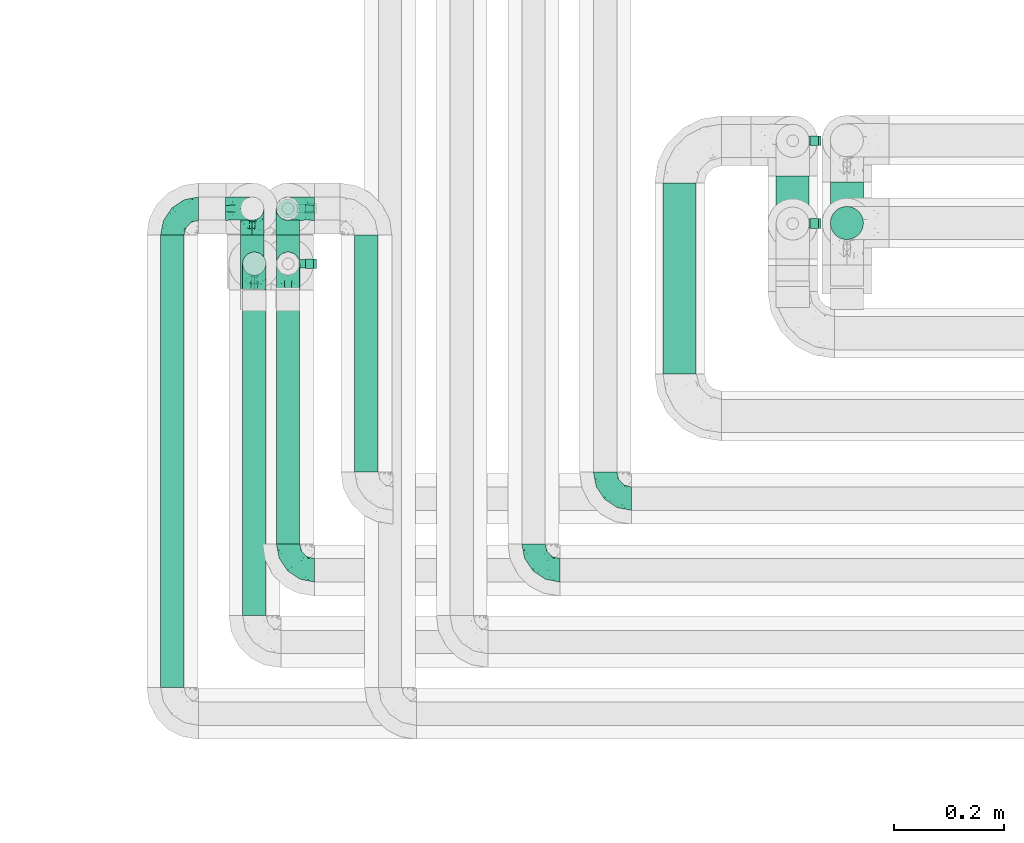
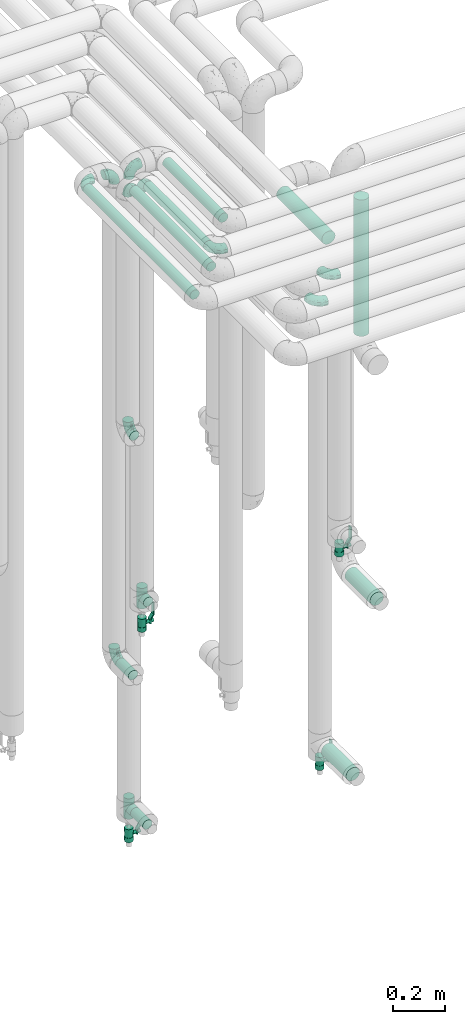
# One storey, part 630 of 827: 12 flow fittings, 10 flow segments, 4 flow controllers.
"""IFC2X3 building model written with IfcOpenShell, lengths in millimetres."""

from ifc_helpers import new_model, entity, si_unit, converted_unit, derived_unit, direction, frame, origin, origin_2d_with_axis, place, context, subcontext, project, spatial, polyline, circle, outline, extrude, faceted_brep, source, transform, mapped, material, material_list, type_object, type_shapes, element, save


model = new_model("IFC2X3")

# Units and contexts
model_context = context("Model", 3, precision=0.01, world=origin(), true_north=direction((6.12303176911189e-17, 1.0)))
body_context = subcontext(model_context, "Body", "Model", "MODEL_VIEW")
ifc_project = project(units=[si_unit("LENGTHUNIT", "METRE", prefix="MILLI"), si_unit("AREAUNIT", "SQUARE_METRE"), si_unit("VOLUMEUNIT", "CUBIC_METRE"), converted_unit("PLANEANGLEUNIT", "DEGREE", entity("IfcRatioMeasure", 0.0174532925199433), si_unit("PLANEANGLEUNIT", "RADIAN"), dimensions=[0, 0, 0, 0, 0, 0, 0]), si_unit("MASSUNIT", "GRAM", prefix="KILO"), derived_unit("MASSDENSITYUNIT", [(si_unit("MASSUNIT", "GRAM", prefix="KILO"), 1), (si_unit("LENGTHUNIT", "METRE"), -3)]), derived_unit("MOMENTOFINERTIAUNIT", [(si_unit("LENGTHUNIT", "METRE"), 4)]), si_unit("TIMEUNIT", "SECOND"), si_unit("FREQUENCYUNIT", "HERTZ"), si_unit("THERMODYNAMICTEMPERATUREUNIT", "DEGREE_CELSIUS"), derived_unit("THERMALTRANSMITTANCEUNIT", [(si_unit("MASSUNIT", "GRAM", prefix="KILO"), 1), (si_unit("THERMODYNAMICTEMPERATUREUNIT", "KELVIN"), -1), (si_unit("TIMEUNIT", "SECOND"), -3)]), derived_unit("VOLUMETRICFLOWRATEUNIT", [(si_unit("LENGTHUNIT", "METRE"), 3), (si_unit("TIMEUNIT", "SECOND"), -1)]), derived_unit("MASSFLOWRATEUNIT", [(si_unit("MASSUNIT", "GRAM", prefix="KILO"), 1), (si_unit("TIMEUNIT", "SECOND"), -1)]), derived_unit("ROTATIONALFREQUENCYUNIT", [(si_unit("TIMEUNIT", "SECOND"), -1)]), si_unit("ELECTRICCURRENTUNIT", "AMPERE"), si_unit("ELECTRICVOLTAGEUNIT", "VOLT"), si_unit("POWERUNIT", "WATT"), si_unit("FORCEUNIT", "NEWTON", prefix="KILO"), si_unit("ILLUMINANCEUNIT", "LUX"), si_unit("LUMINOUSFLUXUNIT", "LUMEN"), si_unit("LUMINOUSINTENSITYUNIT", "CANDELA"), derived_unit("USERDEFINED", [(si_unit("MASSUNIT", "GRAM", prefix="KILO"), -1), (si_unit("LENGTHUNIT", "METRE"), -2), (si_unit("TIMEUNIT", "SECOND"), 3), (si_unit("LUMINOUSFLUXUNIT", "LUMEN"), 1)]), derived_unit("LINEARVELOCITYUNIT", [(si_unit("LENGTHUNIT", "METRE"), 1), (si_unit("TIMEUNIT", "SECOND"), -1)]), si_unit("PRESSUREUNIT", "PASCAL"), derived_unit("USERDEFINED", [(si_unit("LENGTHUNIT", "METRE"), -2), (si_unit("MASSUNIT", "GRAM", prefix="KILO"), 1), (si_unit("TIMEUNIT", "SECOND"), -2)]), derived_unit("LINEARFORCEUNIT", [(si_unit("MASSUNIT", "GRAM", prefix="KILO"), 1), (si_unit("LENGTHUNIT", "METRE"), 1), (si_unit("TIMEUNIT", "SECOND"), -2), (si_unit("LENGTHUNIT", "METRE"), -1)]), derived_unit("PLANARFORCEUNIT", [(si_unit("MASSUNIT", "GRAM", prefix="KILO"), 1), (si_unit("LENGTHUNIT", "METRE"), 1), (si_unit("TIMEUNIT", "SECOND"), -2), (si_unit("LENGTHUNIT", "METRE"), -2)])], contexts=[model_context])

# Site, building, storey
site_placement = place(None, origin())
site = spatial("IfcSite", under=ifc_project, at=site_placement, CompositionType="ELEMENT")
building_placement = place(site_placement, origin())
building = spatial("IfcBuilding", under=site, at=building_placement, CompositionType="ELEMENT")
storey_placement = place(building_placement, frame((0.0, 0.0, 28200.0)))
storey = spatial("IfcBuildingStorey", under=building, at=storey_placement, Name="08", CompositionType="ELEMENT", Elevation=28200.0)

# Flow segments
pipe_segment_type = type_object("IfcPipeSegmentType", PredefinedType="NOTDEFINED")
flow_segment_1_placement = place(storey_placement, frame((31410.16, 14716.0, 2968.4)))
element("IfcFlowSegment", 1, at=flow_segment_1_placement, inside=storey, type_object=pipe_segment_type, context=body_context, shape_type="SweptSolid", body=[
    extrude(circle(Radius=30.0, at=origin_2d_with_axis()), frame((31.6, 0.0, 31.6), z_axis=(0.0, 1.0, 0.0), x_axis=(1.0, 0.0, 0.0)), (0.0, 0.0, 1.0), 347.000400185166),
])
flow_segment_2_placement = place(storey_placement, frame((31713.44, 14871.2, 1078.4)))
element("IfcFlowSegment", 2, at=flow_segment_2_placement, inside=storey, type_object=pipe_segment_type, context=body_context, shape_type="SweptSolid", body=[
    extrude(circle(Radius=30.0, at=origin_2d_with_axis()), frame((31.6, 0.0, 31.6), z_axis=(0.0, 1.0, 0.0), x_axis=(-1.0, 0.0, 0.0)), (0.0, 0.0, 1.0), 192.797683239265),
])
flow_segment_3_placement = place(storey_placement, frame((31615.16, 14885.0, 283.9)))
element("IfcFlowSegment", 3, at=flow_segment_3_placement, inside=storey, type_object=pipe_segment_type, context=body_context, shape_type="SweptSolid", body=[
    extrude(circle(Radius=30.0, at=origin_2d_with_axis()), frame((31.6, 0.0, 31.6), z_axis=(0.0, 1.0, 0.0), x_axis=(-1.0, 0.0, 0.0)), (0.0, 0.0, 1.0), 189.999999999998),
])
flow_segment_4_placement = place(storey_placement, frame((31713.44, 14958.41, 2286.0)))
element("IfcFlowSegment", 4, at=flow_segment_4_placement, inside=storey, type_object=pipe_segment_type, context=body_context, shape_type="SweptSolid", body=[
    extrude(circle(Radius=30.0, at=origin_2d_with_axis()), frame((31.6, 31.6, 0.0)), (0.0, 0.0, 1.0), 638.000000000002),
])
flow_segment_5_placement = place(storey_placement, frame((30647.59, 14278.0, 3377.25)))
element("IfcFlowSegment", 5, at=flow_segment_5_placement, inside=storey, type_object=pipe_segment_type, context=body_context, shape_type="SweptSolid", body=[
    extrude(circle(Radius=21.15, at=origin_2d_with_axis()), frame((22.75, 0.0, 22.75), z_axis=(0.0, 1.0, 0.0), x_axis=(1.0, 0.0, 0.0)), (0.0, 0.0, 1.0), 590.202725945848),
])
flow_segment_6_placement = place(storey_placement, frame((30708.8, 14408.0, 3377.25)))
element("IfcFlowSegment", 6, at=flow_segment_6_placement, inside=storey, type_object=pipe_segment_type, context=body_context, shape_type="SweptSolid", body=[
    extrude(circle(Radius=21.15, at=origin_2d_with_axis()), frame((22.75, 0.0, 22.75), z_axis=(0.0, 1.0, 0.0), x_axis=(1.0, 0.0, 0.0)), (0.0, 0.0, 1.0), 460.202725945847),
])
flow_segment_7_placement = place(storey_placement, frame((30850.8, 14538.0, 3377.25)))
element("IfcFlowSegment", 7, at=flow_segment_7_placement, inside=storey, type_object=pipe_segment_type, context=body_context, shape_type="SweptSolid", body=[
    extrude(circle(Radius=21.15, at=origin_2d_with_axis()), frame((22.75, 0.0, 22.75), z_axis=(0.0, 1.0, 0.0), x_axis=(1.0, 0.0, 0.0)), (0.0, 0.0, 1.0), 430.202725945846),
])
flow_segment_8_placement = place(storey_placement, frame((30498.78, 14148.0, 3377.25)))
element("IfcFlowSegment", 8, at=flow_segment_8_placement, inside=storey, type_object=pipe_segment_type, context=body_context, shape_type="SweptSolid", body=[
    extrude(circle(Radius=21.15, at=origin_2d_with_axis()), frame((22.75, 0.0, 22.75), z_axis=(0.0, 1.0, 0.0), x_axis=(1.0, 0.0, 0.0)), (0.0, 0.0, 1.0), 820.202725945839),
])
flow_segment_9_placement = place(storey_placement, frame((30643.78, 14871.2, 1107.7)))
element("IfcFlowSegment", 9, at=flow_segment_9_placement, inside=storey, type_object=pipe_segment_type, context=body_context, shape_type="SweptSolid", body=[
    extrude(circle(Radius=21.15, at=origin_2d_with_axis()), frame((22.75, 0.0, 22.75), z_axis=(0.0, 1.0, 0.0), x_axis=(-1.0, 0.0, 0.0)), (0.0, 0.0, 1.0), 97.0000000000039),
])
flow_segment_10_placement = place(storey_placement, frame((30708.55, 14873.2, 384.75)))
element("IfcFlowSegment", 10, at=flow_segment_10_placement, inside=storey, type_object=pipe_segment_type, context=body_context, shape_type="SweptSolid", body=[
    extrude(circle(Radius=21.15, at=origin_2d_with_axis()), frame((22.75, 0.0, 22.75), z_axis=(0.0, 1.0, 0.0), x_axis=(-1.0, 0.0, 0.0)), (0.0, 0.0, 1.0), 95.0000000000001),
])

# Flow controllers
ifc_material = material()
ifc_material_list = material_list([ifc_material, ifc_material, ifc_material, ifc_material, ifc_material])
valve_type = type_object("IfcValveType", PredefinedType="NOTDEFINED", material=ifc_material_list)
shared_shape_1 = source(origin(), body_context, "Body", "SweptSolid", [
    extrude(circle(Radius=17.5, at=origin_2d_with_axis()), frame((-30.5, 0.0, 0.0), z_axis=(1.0, 0.0, 0.0), x_axis=(0.0, 1.0, 0.0)), (0.0, 0.0, 1.0), 20.3333333333333),
    extrude(circle(Radius=16.0, at=origin_2d_with_axis()), frame((-10.17, 0.0, 0.0), z_axis=(1.0, 0.0, 0.0), x_axis=(0.0, 1.0, 0.0)), (0.0, 0.0, 1.0), 20.3333333333333),
    extrude(circle(Radius=17.5, at=origin_2d_with_axis()), frame((10.17, 0.0, 0.0), z_axis=(1.0, 0.0, 0.0), x_axis=(0.0, 1.0, 0.0)), (0.0, 0.0, 1.0), 20.3333333333333),
    extrude(outline(polyline([(-38.75, -5.0), (-38.75, -10.0), (-17.92, -10.0), (2.08, 5.0), (56.25, 5.0), (56.25, 10.0), (0.42, 10.0), (-19.58, -5.0), (-38.75, -5.0)])), frame((28.75, -8.75, 41.5), z_axis=(0.0, -1.0, 0.0), x_axis=(1.0, 0.0, 0.0)), (0.0, 0.0, -1.0), 17.5),
    extrude(circle(Radius=8.0, at=origin_2d_with_axis()), origin(), (0.0, 0.0, 1.0), 49.0),
])
type_shapes(valve_type, [shared_shape_1])
for number, where, z_axis, x_axis in (
    (11, (31646.75, 15139.0, 221.0), (1.0, 0.0, 0.0), (0.0, 0.0, 1.0)),
    (12, (31646.75, 14989.0, 1311.0), (1.0, 0.0, 0.0), (0.0, 0.0, 1.0)),
    (13, (30731.54, 14916.2, 1323.0), (1.0, 0.0, 0.0), (0.0, 0.0, 1.0)),
    (14, (30731.3, 15016.2, 278.0), (1.0, 0.0, 0.0), (0.0, 0.0, 1.0)),
):
    element("IfcFlowController", number, at=place(storey_placement, frame(where, z_axis=z_axis, x_axis=x_axis)), inside=storey, type_object=valve_type, material=ifc_material, context=body_context, shape_type="MappedRepresentation", body=[
        mapped(shared_shape_1, transform((0.0, 0.0, 0.0), scale=1.0)),
    ])

# Flow fittings
pipe_fitting_type_1 = type_object("IfcPipeFittingType", Name="ADSK_1", PredefinedType="NOTDEFINED", material=ifc_material)
shared_shape_2 = source(origin(), body_context, "Body", "Brep", [
    faceted_brep([(-48.0, 10.6, -18.36), (-48.0, 5.49, -20.48), (-48.0, 0.0, -21.2), (-48.0, -5.49, -20.48), (-48.0, -10.6, -18.36), (-48.0, -14.99, -14.99), (-48.0, -18.36, -10.6), (-48.0, -20.48, -5.49), (-48.0, -21.2, 0.0), (-48.0, -20.48, 5.49), (-48.0, -18.36, 10.6), (-48.0, -14.99, 14.99), (-48.0, -10.6, 18.36), (-48.0, -5.49, 20.48), (-48.0, 0.0, 21.2), (-48.0, 5.49, 20.48), (-48.0, 10.6, 18.36), (-48.0, 14.99, 14.99), (-48.0, 18.36, 10.6), (-48.0, 20.48, 5.49), (-48.0, 21.2, 0.0), (-48.0, 20.48, -5.49), (-48.0, 18.36, -10.6), (-48.0, 14.99, -14.99), (0.0, 48.0, -21.2), (-5.49, 48.0, -20.48), (-10.6, 48.0, -18.36), (-14.99, 48.0, -14.99), (-18.36, 48.0, -10.6), (-20.48, 48.0, -5.49), (-21.2, 48.0, 0.0), (-20.48, 48.0, 5.49), (-18.36, 48.0, 10.6), (-14.99, 48.0, 14.99), (-10.6, 48.0, 18.36), (-5.49, 48.0, 20.48), (0.0, 48.0, 21.2), (5.49, 48.0, 20.48), (10.6, 48.0, 18.36), (14.99, 48.0, 14.99), (18.36, 48.0, 10.6), (20.48, 48.0, 5.49), (21.2, 48.0, 0.0), (20.48, 48.0, -5.49), (18.36, 48.0, -10.6), (14.99, 48.0, -14.99), (10.6, 48.0, -18.36), (5.49, 48.0, -20.48), (-35.25, -16.22, 12.01), (-34.76, -18.57, 0.0), (-20.87, -12.37, 10.9), (-31.49, -11.78, 15.9), (-37.0, -2.58, 20.86), (-33.89, 3.62, 21.15), (-31.81, -18.14, 6.76), (-5.78, 5.78, 17.67), (-19.42, -4.1, 17.86), (-9.6, -3.39, 13.73), (-35.44, -7.73, 19.13), (11.78, 31.49, 15.9), (-5.93, -5.46, 6.95), (-18.45, -13.78, 5.46), (-10.29, -8.43, 0.0), (-24.6, 0.55, 20.62), (-37.28, 17.94, 13.81), (-33.38, 22.85, 9.59), (-41.46, 20.06, 8.75), (-29.51, 20.45, 15.16), (-15.04, 10.79, 21.13), (-7.08, 16.98, 20.93), (-8.39, 23.51, 21.15), (-40.86, 13.03, 17.26), (-8.05, 41.26, 19.83), (-3.21, 35.97, 21.14), (8.53, 19.66, 14.74), (4.1, 19.42, 17.86), (-37.72, 22.66, 4.78), (-37.07, 8.58, 19.98), (-13.0, 5.43, 19.97), (-3.78, 13.93, 19.7), (3.02, 8.69, 13.43), (-2.27, -0.05, 10.65), (6.22, 6.99, 7.09), (-22.25, 34.6, 9.45), (18.14, 31.81, 6.76), (16.22, 35.25, 12.01), (12.37, 20.87, 10.9), (7.73, 35.44, 19.13), (-21.52, -15.93, 0.0), (2.58, 37.0, 20.86), (18.57, 34.76, 0.0), (13.78, 18.45, 5.46), (15.93, 21.52, 0.0), (-20.03, -8.54, 14.9), (-28.6, 28.6, 5.16), (-24.79, 34.6, 0.0), (-34.6, 24.79, 0.0), (-22.81, 37.41, 4.68), (-23.36, 26.33, 14.79), (-13.68, 37.05, 17.49), (-17.72, 38.12, 13.73), (-26.25, 27.3, 11.24), (-9.71, 32.34, 20.14), (-17.26, 25.6, 18.71), (-26.33, 9.99, 20.77), (-24.06, 6.05, 21.2), (-25.02, 15.46, 19.56), (-24.3, 20.72, 17.57), (-31.95, 15.23, 17.8), (-13.53, 24.7, 20.21), (-17.6, 17.6, 20.6), (-0.55, 24.6, 20.62), (-11.41, -7.48, 10.43), (0.93, -0.93, 0.0), (8.43, 10.29, 0.0), (-11.41, -7.48, -10.43), (-20.1, -8.84, -14.66), (-9.6, -3.39, -13.73), (7.73, 35.44, -19.13), (4.1, 19.42, -17.86), (-0.55, 24.6, -20.62), (-38.12, 17.72, -13.73), (-37.05, 13.68, -17.49), (-32.34, 9.71, -20.14), (-41.26, 8.05, -19.83), (-37.41, 22.81, -4.68), (-23.51, 8.39, -21.15), (-35.97, 3.21, -21.14), (-28.6, 28.6, -5.16), (-31.81, -18.14, -6.76), (-18.45, -13.78, -5.46), (-25.6, 17.26, -18.71), (-19.42, -4.1, -17.86), (-17.94, 37.28, -13.81), (-22.85, 33.38, -9.59), (-20.06, 41.46, -8.75), (-31.49, -11.78, -15.9), (-35.25, -16.22, -12.01), (8.53, 19.66, -14.74), (11.78, 31.49, -15.9), (-9.99, 26.33, -20.77), (-6.05, 24.06, -21.2), (-10.79, 15.04, -21.13), (-37.0, -2.58, -20.86), (-16.98, 7.08, -20.93), (-5.43, 13.0, -19.97), (-13.93, 3.78, -19.7), (-20.87, -12.37, -10.9), (-26.33, 23.36, -14.79), (-22.66, 37.72, -4.78), (13.78, 18.45, -5.46), (18.14, 31.81, -6.76), (-15.46, 25.02, -19.56), (-20.72, 24.3, -17.57), (16.22, 35.25, -12.01), (-13.03, 40.86, -17.26), (-8.58, 37.07, -19.98), (2.58, 37.0, -20.86), (-3.62, 33.89, -21.15), (-34.6, 22.25, -9.45), (6.22, 6.99, -7.09), (-20.45, 29.51, -15.16), (-35.44, -7.73, -19.13), (12.37, 20.87, -10.9), (-27.3, 26.25, -11.24), (-15.23, 31.95, -17.8), (-24.7, 13.53, -20.21), (-24.6, 0.55, -20.62), (-5.78, 5.78, -17.67), (-17.6, 17.6, -20.6), (3.02, 8.69, -13.43), (-5.93, -5.46, -6.95), (-2.27, -0.05, -10.65)], [[[0, 1, 2, 3, 4, 5, 6, 7, 8, 9, 10, 11, 12, 13, 14, 15, 16, 17, 18, 19, 20, 21, 22, 23]], [[24, 25, 26, 27, 28, 29, 30, 31, 32, 33, 34, 35, 36, 37, 38, 39, 40, 41, 42, 43, 44, 45, 46, 47]], [[10, 48, 11]], [[9, 8, 49]], [[48, 50, 51]], [[14, 52, 53]], [[10, 54, 48]], [[9, 54, 10]], [[55, 56, 57]], [[51, 12, 11]], [[51, 58, 12]], [[59, 39, 38]], [[60, 61, 62]], [[58, 56, 63]], [[64, 65, 66]], [[67, 65, 64]], [[68, 69, 70]], [[16, 71, 17]], [[13, 52, 14]], [[35, 72, 73]], [[14, 53, 15]], [[17, 64, 18]], [[74, 59, 75]], [[20, 19, 76]], [[66, 19, 18]], [[77, 15, 53]], [[15, 77, 16]], [[69, 78, 79]], [[80, 81, 82]], [[32, 31, 83]], [[84, 85, 86]], [[59, 87, 75]], [[61, 54, 88]], [[36, 89, 37]], [[84, 41, 40]], [[36, 35, 73]], [[90, 41, 84]], [[40, 39, 85]], [[12, 58, 13]], [[85, 84, 40]], [[91, 84, 86]], [[84, 92, 90]], [[87, 38, 37]], [[93, 56, 51]], [[65, 94, 76]], [[94, 95, 96]], [[84, 91, 92]], [[95, 97, 30]], [[98, 99, 100]], [[76, 94, 96]], [[101, 98, 83]], [[100, 99, 33]], [[102, 70, 73]], [[103, 102, 99]], [[94, 97, 95]], [[72, 99, 102]], [[72, 35, 34]], [[34, 33, 99]], [[9, 49, 54]], [[87, 59, 38]], [[104, 105, 68]], [[106, 103, 107]], [[106, 77, 104]], [[71, 64, 17]], [[108, 107, 67]], [[33, 32, 100]], [[109, 103, 110]], [[102, 109, 70]], [[89, 73, 111]], [[50, 48, 54]], [[51, 11, 48]], [[56, 58, 51]], [[88, 54, 49]], [[52, 58, 63]], [[50, 112, 93]], [[56, 55, 78]], [[39, 59, 85]], [[86, 85, 59]], [[89, 87, 37]], [[42, 41, 90]], [[111, 79, 75]], [[111, 75, 87]], [[75, 55, 80]], [[104, 77, 53]], [[71, 77, 108]], [[32, 83, 100]], [[98, 100, 83]], [[99, 98, 103]], [[106, 107, 108]], [[68, 70, 110]], [[111, 73, 70]], [[68, 110, 104]], [[68, 63, 78]], [[57, 93, 112]], [[80, 55, 57]], [[61, 50, 54]], [[80, 82, 86]], [[81, 57, 112]], [[74, 86, 59]], [[60, 113, 82]], [[82, 114, 91]], [[101, 94, 65]], [[97, 94, 83]], [[73, 89, 36]], [[87, 89, 111]], [[58, 52, 13]], [[53, 52, 63]], [[104, 53, 105]], [[106, 104, 110]], [[20, 76, 96]], [[76, 19, 66]], [[103, 106, 110]], [[77, 106, 108]], [[103, 98, 107]], [[67, 107, 98]], [[67, 98, 101]], [[108, 67, 64]], [[53, 63, 105]], [[63, 68, 105]], [[83, 31, 97]], [[30, 97, 31]], [[62, 113, 60]], [[112, 61, 60]], [[61, 88, 62]], [[86, 82, 91]], [[56, 78, 63]], [[114, 82, 113]], [[114, 92, 91]], [[79, 78, 55]], [[75, 79, 55]], [[69, 79, 111]], [[70, 69, 111]], [[78, 69, 68]], [[77, 71, 16]], [[64, 71, 108]], [[64, 66, 18]], [[76, 66, 65]], [[99, 72, 34]], [[73, 72, 102]], [[94, 101, 83]], [[67, 101, 65]], [[75, 80, 74]], [[80, 86, 74]], [[70, 109, 110]], [[102, 103, 109]], [[50, 93, 51]], [[57, 56, 93]], [[61, 112, 50]], [[81, 112, 60]], [[82, 81, 60]], [[80, 57, 81]], [[115, 116, 117]], [[118, 119, 120]], [[121, 122, 23]], [[123, 124, 122]], [[96, 125, 20]], [[123, 126, 127]], [[128, 96, 95]], [[129, 130, 88]], [[123, 122, 131]], [[116, 132, 117]], [[133, 134, 135]], [[0, 124, 1]], [[5, 136, 137]], [[138, 119, 139]], [[129, 88, 49]], [[140, 141, 142]], [[6, 5, 137]], [[46, 118, 47]], [[143, 3, 2]], [[144, 145, 146]], [[6, 129, 7]], [[129, 137, 147]], [[127, 2, 1]], [[148, 122, 121]], [[128, 125, 96]], [[134, 128, 149]], [[95, 149, 128]], [[150, 151, 92]], [[30, 29, 149]], [[152, 131, 153]], [[27, 133, 28]], [[154, 45, 44]], [[136, 5, 4]], [[27, 26, 155]], [[156, 26, 25]], [[24, 157, 158]], [[24, 47, 157]], [[22, 21, 159]], [[160, 150, 114]], [[134, 133, 161]], [[142, 144, 126]], [[46, 139, 118]], [[162, 136, 4]], [[156, 25, 158]], [[1, 124, 127]], [[115, 147, 116]], [[45, 154, 139]], [[139, 46, 45]], [[154, 163, 139]], [[162, 4, 3]], [[42, 90, 43]], [[130, 129, 147]], [[49, 7, 129]], [[43, 151, 44]], [[0, 23, 122]], [[24, 158, 25]], [[136, 162, 132]], [[135, 29, 28]], [[43, 90, 151]], [[164, 148, 159]], [[152, 156, 140]], [[155, 133, 27]], [[165, 153, 161]], [[23, 22, 121]], [[123, 131, 166]], [[123, 166, 126]], [[143, 127, 167]], [[147, 137, 136]], [[8, 7, 49]], [[129, 6, 137]], [[143, 162, 3]], [[167, 146, 132]], [[167, 132, 162]], [[132, 168, 117]], [[44, 151, 154]], [[92, 151, 90]], [[163, 154, 151]], [[119, 118, 139]], [[157, 118, 120]], [[138, 139, 163]], [[119, 168, 145]], [[140, 156, 158]], [[155, 156, 165]], [[22, 159, 121]], [[148, 121, 159]], [[122, 148, 131]], [[152, 153, 165]], [[142, 126, 169]], [[167, 127, 126]], [[142, 169, 140]], [[142, 120, 145]], [[168, 170, 117]], [[160, 171, 172]], [[115, 172, 171]], [[171, 62, 130]], [[119, 170, 168]], [[170, 163, 160]], [[150, 163, 151]], [[113, 171, 160]], [[164, 128, 134]], [[125, 128, 159]], [[127, 143, 2]], [[162, 143, 167]], [[118, 157, 47]], [[158, 157, 120]], [[140, 158, 141]], [[152, 140, 169]], [[30, 149, 95]], [[149, 29, 135]], [[131, 152, 169]], [[156, 152, 165]], [[131, 148, 153]], [[161, 153, 148]], [[161, 148, 164]], [[165, 161, 133]], [[158, 120, 141]], [[120, 142, 141]], [[159, 21, 125]], [[20, 125, 21]], [[115, 130, 147]], [[114, 113, 160]], [[62, 171, 113]], [[62, 88, 130]], [[160, 163, 150]], [[150, 92, 114]], [[119, 145, 120]], [[146, 145, 168]], [[132, 146, 168]], [[144, 146, 167]], [[126, 144, 167]], [[145, 144, 142]], [[156, 155, 26]], [[133, 155, 165]], [[133, 135, 28]], [[149, 135, 134]], [[122, 124, 0]], [[127, 124, 123]], [[128, 164, 159]], [[161, 164, 134]], [[163, 170, 138]], [[170, 119, 138]], [[131, 169, 166]], [[126, 166, 169]], [[147, 136, 116]], [[132, 116, 136]], [[172, 115, 117]], [[130, 115, 171]], [[117, 170, 172]], [[160, 172, 170]]]),
])
type_shapes(pipe_fitting_type_1, [shared_shape_2])
for number, where, z_axis, x_axis, name in (
    (15, (31306.52, 14490.0, 3000.0), (0.0, 0.0, 1.0), (0.0, -1.0, 0.0), "ADSK_1"),
    (16, (31176.52, 14360.0, 3000.0), (0.0, 0.0, 1.0), (0.0, -1.0, 0.0), "ADSK_1"),
    (17, (30731.54, 14360.0, 3400.0), (0.0, 0.0, 1.0), (0.0, -1.0, 0.0), "ADSK_1"),
    (18, (30731.3, 15016.2, 3400.0), (0.0, -1.0, 0.0), (-1.0, 0.0, 0.0), "ADSK_1"),
    (19, (30731.54, 14916.2, 3400.0), (-1.0, 0.0, 0.0), (0.0, 1.0, 0.0), "ADSK_1"),
    (20, (30670.34, 14916.2, 3400.0), (-1.0, 0.0, 0.0), (0.0, 1.0, 0.0), "ADSK_1"),
    (21, (30521.52, 15016.2, 3400.0), (0.0, 0.0, 1.0), (-1.0, 0.0, 0.0), "ADSK_1"),
    (22, (30666.52, 15016.2, 3400.0), (0.0, 1.0, 0.0), (1.0, 0.0, 0.0), "ADSK_1"),
    (23, (30670.34, 14916.2, 2250.45), (-1.0, 0.0, 0.0), (0.0, 0.0, -1.0), "ADSK_1"),
    (24, (30666.52, 15016.2, 1130.45), (-1.0, 0.0, 0.0), (0.0, 0.0, -1.0), "ADSK_1"),
):
    element("IfcFlowFitting", number, at=place(storey_placement, frame(where, z_axis=z_axis, x_axis=x_axis)), inside=storey, type_object=pipe_fitting_type_1, material=ifc_material, Name=name, ObjectType="ADSK_1", context=body_context, shape_type="MappedRepresentation", body=[
        mapped(shared_shape_2, transform((0.0, 0.0, 0.0), scale=1.0)),
    ])
pipe_fitting_type_2 = type_object("IfcPipeFittingType", Name="ADSK_1", PredefinedType="NOTDEFINED", material=ifc_material)
shared_shape_3 = source(origin(), body_context, "Body", "Brep", [
    faceted_brep([(-48.0, 10.6, -18.36), (-48.0, 5.49, -20.48), (-48.0, 0.0, -21.2), (-48.0, -5.49, -20.48), (-48.0, -10.6, -18.36), (-48.0, -14.99, -14.99), (-48.0, -18.36, -10.6), (-48.0, -20.48, -5.49), (-48.0, -21.2, 0.0), (-48.0, -20.48, 5.49), (-48.0, -18.36, 10.6), (-48.0, -14.99, 14.99), (-48.0, -10.6, 18.36), (-48.0, -5.49, 20.48), (-48.0, 0.0, 21.2), (-48.0, 5.49, 20.48), (-48.0, 10.6, 18.36), (-48.0, 14.99, 14.99), (-48.0, 18.36, 10.6), (-48.0, 20.48, 5.49), (-48.0, 21.2, 0.0), (-48.0, 20.48, -5.49), (-48.0, 18.36, -10.6), (-48.0, 14.99, -14.99), (48.0, 0.0, -21.2), (48.0, 5.49, -20.48), (48.0, 10.6, -18.36), (48.0, 14.99, -14.99), (48.0, 18.36, -10.6), (48.0, 20.48, -5.49), (48.0, 21.2, 0.0), (48.0, 20.48, 5.49), (48.0, 18.36, 10.6), (48.0, 14.99, 14.99), (48.0, 10.6, 18.36), (48.0, 5.49, 20.48), (48.0, 0.0, 21.2), (48.0, -5.49, 20.48), (48.0, -10.6, 18.36), (48.0, -14.99, 14.99), (48.0, -18.36, 10.6), (48.0, -20.48, 5.49), (48.0, -21.2, 0.0), (48.0, -20.48, -5.49), (48.0, -18.36, -10.6), (48.0, -14.99, -14.99), (48.0, -10.6, -18.36), (48.0, -5.49, -20.48), (20.43, -20.43, 5.66), (21.2, -21.2, 0.0), (-21.2, -21.2, 0.0), (18.35, -18.35, 10.62), (11.88, -11.88, 17.56), (15.38, -15.38, 14.59), (-20.43, -20.43, 5.66), (-18.35, -18.35, 10.62), (-15.38, -15.38, 14.59), (-11.88, -11.88, 17.56), (-8.06, -8.06, 19.61), (8.06, -8.06, 19.61), (4.07, -4.07, 20.81), (0.0, 0.0, 21.2), (-4.07, -4.07, 20.81), (4.07, -4.07, -20.81), (0.0, 0.0, -21.2), (-4.07, -4.07, -20.81), (-8.06, -8.06, -19.61), (8.06, -8.06, -19.61), (11.88, -11.88, -17.56), (15.38, -15.38, -14.59), (18.35, -18.35, -10.62), (20.43, -20.43, -5.66), (-11.88, -11.88, -17.56), (-15.38, -15.38, -14.59), (-20.43, -20.43, -5.66), (-18.35, -18.35, -10.62), (0.0, -48.0, -21.2), (5.49, -48.0, -20.48), (10.6, -48.0, -18.36), (14.99, -48.0, -14.99), (18.36, -48.0, -10.6), (20.48, -48.0, -5.49), (21.2, -48.0, 0.0), (20.48, -48.0, 5.49), (18.36, -48.0, 10.6), (14.99, -48.0, 14.99), (10.6, -48.0, 18.36), (5.49, -48.0, 20.48), (0.0, -48.0, 21.2), (-5.49, -48.0, 20.48), (-10.6, -48.0, 18.36), (-14.99, -48.0, 14.99), (-18.36, -48.0, 10.6), (-20.48, -48.0, 5.49), (-21.2, -48.0, 0.0), (-20.48, -48.0, -5.49), (-18.36, -48.0, -10.6), (-14.99, -48.0, -14.99), (-10.6, -48.0, -18.36), (-5.49, -48.0, -20.48)], [[[0, 1, 2, 3, 4, 5, 6, 7, 8, 9, 10, 11, 12, 13, 14, 15, 16, 17, 18, 19, 20, 21, 22, 23]], [[24, 25, 26, 27, 28, 29, 30, 31, 32, 33, 34, 35, 36, 37, 38, 39, 40, 41, 42, 43, 44, 45, 46, 47]], [[41, 40, 48]], [[42, 41, 49]], [[50, 9, 8]], [[49, 41, 48]], [[40, 51, 48]], [[39, 38, 52]], [[51, 40, 53]], [[52, 53, 39]], [[53, 40, 39]], [[50, 54, 9]], [[9, 54, 10]], [[54, 55, 10]], [[56, 57, 11]], [[11, 10, 56]], [[11, 57, 12]], [[56, 10, 55]], [[12, 57, 58]], [[52, 38, 59]], [[60, 36, 61]], [[62, 61, 14]], [[59, 37, 60]], [[37, 59, 38]], [[60, 37, 36]], [[61, 36, 35, 15, 14]], [[32, 31, 19, 18]], [[17, 16, 34, 33]], [[18, 17, 33, 32]], [[35, 34, 16, 15]], [[20, 19, 31, 30]], [[62, 13, 58]], [[13, 62, 14]], [[58, 13, 12]], [[27, 23, 22, 28]], [[22, 21, 29, 28]], [[0, 23, 27, 26]], [[20, 30, 29, 21]], [[24, 47, 63]], [[24, 64, 2, 1, 25]], [[64, 24, 63]], [[2, 64, 65]], [[26, 25, 1, 0]], [[65, 66, 3]], [[2, 65, 3]], [[66, 4, 3]], [[63, 47, 67]], [[46, 45, 68]], [[69, 68, 45]], [[44, 70, 69]], [[69, 45, 44]], [[46, 68, 67]], [[43, 42, 49]], [[7, 50, 8]], [[43, 71, 44]], [[71, 43, 49]], [[44, 71, 70]], [[72, 4, 66]], [[72, 5, 4]], [[5, 72, 73]], [[5, 73, 6]], [[74, 50, 7]], [[75, 74, 6]], [[74, 7, 6]], [[75, 6, 73]], [[46, 67, 47]], [[76, 77, 78, 79, 80, 81, 82, 83, 84, 85, 86, 87, 88, 89, 90, 91, 92, 93, 94, 95, 96, 97, 98, 99]], [[50, 94, 93]], [[54, 50, 93]], [[91, 90, 57]], [[56, 92, 91]], [[54, 93, 92]], [[58, 90, 89]], [[55, 54, 92]], [[56, 55, 92]], [[58, 57, 90]], [[88, 61, 62]], [[58, 89, 62]], [[56, 91, 57]], [[62, 89, 88]], [[60, 88, 87]], [[86, 59, 87]], [[84, 83, 48]], [[53, 85, 84]], [[52, 86, 85]], [[49, 83, 82]], [[59, 60, 87]], [[52, 59, 86]], [[49, 48, 83]], [[51, 53, 84]], [[48, 51, 84]], [[52, 85, 53]], [[88, 60, 61]], [[82, 81, 49]], [[71, 49, 81]], [[69, 80, 79]], [[79, 78, 68]], [[71, 81, 80]], [[67, 78, 77]], [[70, 71, 80]], [[69, 70, 80]], [[67, 68, 78]], [[76, 64, 63]], [[67, 77, 63]], [[69, 79, 68]], [[63, 77, 76]], [[65, 76, 99]], [[98, 66, 99]], [[96, 95, 74]], [[73, 97, 96]], [[72, 98, 97]], [[50, 95, 94]], [[66, 65, 99]], [[72, 66, 98]], [[50, 74, 95]], [[75, 73, 96]], [[74, 75, 96]], [[72, 97, 73]], [[76, 65, 64]]]),
])
type_shapes(pipe_fitting_type_2, [shared_shape_3])
for number, where, z_axis, x_axis, name in (
    (25, (30731.54, 14916.2, 1452.5), (1.0, 0.0, 0.0), (0.0, 0.0, -1.0), "ADSK_1"),
    (26, (30731.3, 15016.2, 407.5), (1.0, 0.0, 0.0), (0.0, 0.0, -1.0), "ADSK_1"),
):
    element("IfcFlowFitting", number, at=place(storey_placement, frame(where, z_axis=z_axis, x_axis=x_axis)), inside=storey, type_object=pipe_fitting_type_2, material=ifc_material, Name=name, ObjectType="ADSK_1", context=body_context, shape_type="MappedRepresentation", body=[
        mapped(shared_shape_3, transform((0.0, 0.0, 0.0), scale=1.0)),
    ])

save(model, "model.ifc")
